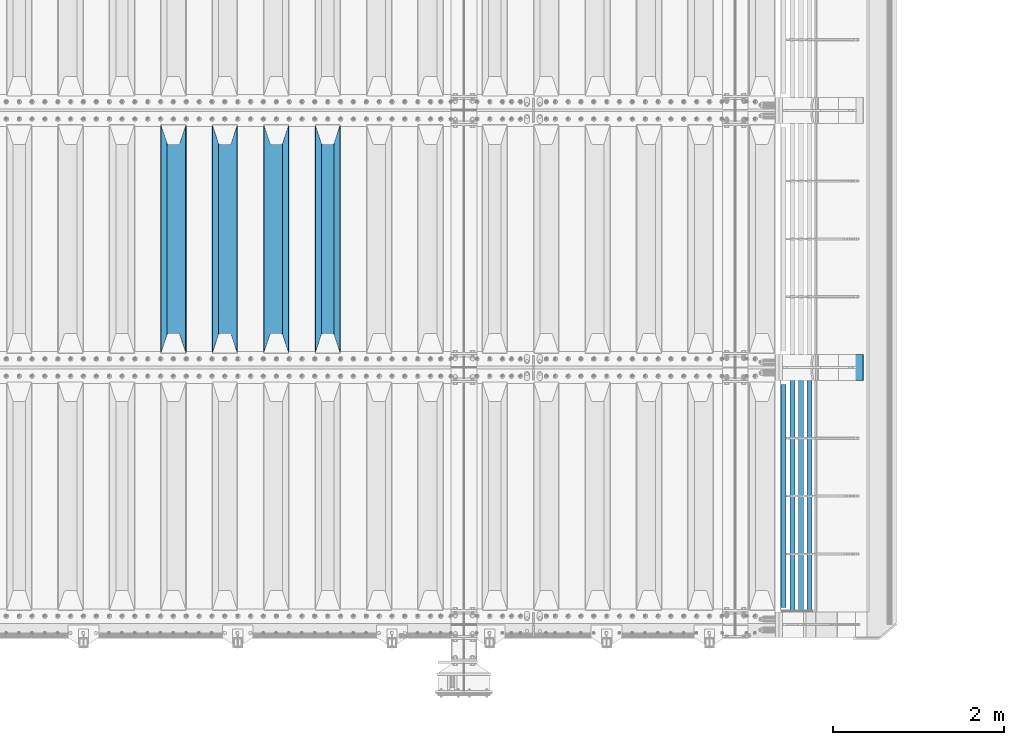
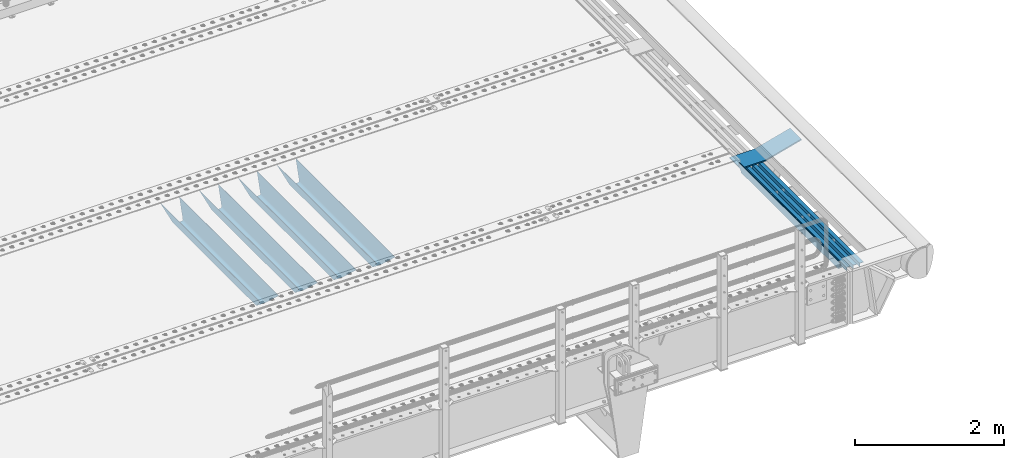
# One storey, part 109 of 240: 9 beams.
"""IFC2X3 building model written with IfcOpenShell, lengths in millimetres."""

from ifc_helpers import new_model, si_unit, frame, origin_with_axes, place, context, subcontext, project, spatial, faceted_brep, material, type_object, element, save


model = new_model("IFC2X3")

# Units and contexts
model_context = context("Model", 3, precision=1e-05, world=origin_with_axes())
body_context = subcontext(model_context, "Body", "Model", "MODEL_VIEW")
ifc_project = project(units=[si_unit("LENGTHUNIT", "METRE", prefix="MILLI"), si_unit("AREAUNIT", "SQUARE_METRE"), si_unit("VOLUMEUNIT", "CUBIC_METRE"), si_unit("MASSUNIT", "GRAM", prefix="KILO"), si_unit("TIMEUNIT", "SECOND"), si_unit("PLANEANGLEUNIT", "RADIAN"), si_unit("SOLIDANGLEUNIT", "STERADIAN"), si_unit("THERMODYNAMICTEMPERATUREUNIT", "DEGREE_CELSIUS"), si_unit("LUMINOUSINTENSITYUNIT", "LUMEN")], contexts=[model_context])

# Site, building, storey
site_placement = place(None, origin_with_axes())
site = spatial("IfcSite", under=ifc_project, at=site_placement, CompositionType="ELEMENT")
building_placement = place(site_placement, origin_with_axes())
building = spatial("IfcBuilding", under=site, at=building_placement, Name="Standard", CompositionType="ELEMENT")
storey_placement = place(building_placement, origin_with_axes())
storey = spatial("IfcBuildingStorey", under=building, at=storey_placement, Name="Undefined", CompositionType="ELEMENT", Elevation=0.0)

# Beams
ifc_material_1 = material(Name="STEEL/S355N")
beam_type_1 = type_object("IfcBeamType", PredefinedType="NOTDEFINED")
beam_1_placement = place(storey_placement, frame((51250.0, 27175.0, -115.0), z_axis=(0.0, 0.0, 1.0), x_axis=(0.0, 1.0, 0.0)))
element("IfcBeam", 1, at=beam_1_placement, inside=storey, type_object=beam_type_1, material=ifc_material_1, context=body_context, shape_type="Brep", body=[
    faceted_brep([(0.0, 150.0, 115.0), (0.0, 143.690000000002, 115.0), (2650.00000000297, 143.690000000002, 115.0), (2650.00000000297, 150.0, 115.0), (2650.00000000297, 142.059565218406, 110.000000003094), (2650.00000000297, 148.369565218403, 110.000000003094), (2441.90079219209, -80.1103600731149, -98.0992078077845), (2437.7588105432, -77.5672621345584, -102.241189456673), (2434.06523489747, -74.4080125315522, -105.934765102404), (2430.9108609509, -70.7102721255724, -109.089139048974), (2428.37322971128, -66.5649389910031, -111.626770288588), (2426.51472138055, -62.0739139532889, -113.485278619323), (2425.38102192092, -57.3475956567636, -114.618978078955), (2424.99999999987, -52.5021667386536, -115.0), (2424.99999999987, 52.5021667386536, -115.0), (2425.38102192092, 57.3475956567636, -114.618978078955), (2426.51472138055, 62.0739139532889, -113.485278619323), (2428.37322971128, 66.5649389910031, -111.626770288588), (2430.9108609509, 70.7102721255724, -109.089139048974), (2434.06523489747, 74.4080125315522, -105.934765102404), (2437.7588105432, 77.5672621345584, -102.241189456673), (2441.90079219209, 80.1103600731149, -98.0992078077846), (2446.38936140512, 81.9747917625791, -93.6106385947584), (2448.2494850041, 76.2713538057287, -91.7505149957729), (2444.62967112263, 74.76777986261, -95.3703288772456), (2441.28936334127, 72.7168944282894, -98.710636658607), (2438.31067330439, 70.1691124903809, -101.689326695487), (2435.76682334748, 67.1870637758839, -104.233176652398), (2433.72034654134, 63.8440531834931, -106.279653458539), (2432.22154950042, 60.2222587982324, -107.778450499454), (2431.30727574265, 56.4107117849126, -108.692724257221), (2430.99999999987, 52.5031078186876, -109.0), (2430.99999999987, -52.5031078186876, -109.0), (2431.30727574265, -56.4107117849126, -108.692724257221), (2432.22154950042, -60.2222587982324, -107.778450499454), (2433.72034654134, -63.8440531834931, -106.279653458539), (2435.76682334748, -67.1870637758839, -104.233176652398), (2438.31067330439, -70.1691124903809, -101.689326695487), (2441.28936334127, -72.7168944282894, -98.7106366586071), (2444.62967112263, -74.76777986261, -95.3703288772457), (2448.2494850041, -76.2713538057287, -91.7505149957729), (2650.00000000297, -142.059565218406, 110.000000003094), (2650.00000000297, -148.369565218403, 110.000000003094), (2446.38936140512, -81.9747917625791, -93.6106385947584), (2650.00000000297, -143.690000000002, 115.0), (2650.00000000297, -150.0, 115.0), (0.0, -143.690000000002, 115.0), (0.0, -150.0, 115.0), (0.0, -148.369565218258, 110.000000002667), (203.610638597427, -81.9747917625791, -93.6106385947584), (208.09920781045, -80.1103600731149, -98.0992078077845), (212.241189459342, -77.5672621345584, -102.241189456673), (215.93476510507, -74.4080125315522, -105.934765102404), (219.089139051641, -70.7102721255724, -109.089139048974), (221.626770291256, -66.5649389910031, -111.626770288588), (223.485278621989, -62.0739139532889, -113.485278619323), (224.618978081624, -57.3475956567636, -114.618978078955), (225.000000002663, -52.5021667386536, -115.0), (225.000000002663, 52.5021667386536, -115.0), (224.618978081624, 57.3475956567636, -114.618978078955), (223.485278621989, 62.0739139532889, -113.485278619323), (221.626770291256, 66.5649389910031, -111.626770288588), (219.089139051641, 70.7102721255724, -109.089139048974), (215.93476510507, 74.4080125315522, -105.934765102404), (212.241189459342, 77.5672621345584, -102.241189456673), (208.09920781045, 80.1103600731149, -98.0992078077846), (203.610638597427, 81.9747917625791, -93.6106385947584), (0.0, 148.369565218258, 110.000000002667), (0.0, 142.05956521826, 110.000000002667), (201.750514998439, 76.2713538057287, -91.7505149957729), (205.370328879908, 74.76777986261, -95.3703288772456), (208.710636661275, 72.7168944282894, -98.710636658607), (211.689326698153, 70.1691124903809, -101.689326695487), (214.233176655063, 67.1870637758839, -104.233176652398), (216.279653461206, 63.8440531834931, -106.279653458539), (217.778450502123, 60.2222587982324, -107.778450499454), (218.692724259887, 56.4107117849126, -108.692724257221), (219.000000002667, 52.5031078186876, -109.0), (219.000000002667, -52.5031078186876, -109.0), (218.692724259887, -56.4107117849126, -108.692724257221), (217.778450502123, -60.2222587982324, -107.778450499454), (216.279653461206, -63.8440531834931, -106.279653458539), (214.233176655063, -67.1870637758839, -104.233176652398), (211.689326698153, -70.1691124903809, -101.689326695487), (208.710636661275, -72.7168944282894, -98.7106366586071), (205.370328879915, -74.76777986261, -95.3703288772457), (201.750514998439, -76.2713538057287, -91.7505149957729), (0.0, -142.05956521826, 110.000000002667)], [[[0, 1, 2, 3]], [[3, 2, 4, 5]], [[6, 7, 8, 9, 10, 11, 12, 13, 14, 15, 16, 17, 18, 19, 20, 21, 22, 5, 4, 23, 24, 25, 26, 27, 28, 29, 30, 31, 32, 33, 34, 35, 36, 37, 38, 39, 40, 41, 42, 43]], [[44, 45, 42, 41]], [[46, 47, 45, 44]], [[43, 42, 45, 47, 48, 49]], [[6, 43, 49, 50]], [[7, 6, 50, 51]], [[8, 7, 51, 52]], [[9, 8, 52, 53]], [[10, 9, 53, 54]], [[11, 10, 54, 55]], [[12, 11, 55, 56]], [[13, 12, 56, 57]], [[14, 13, 57, 58]], [[15, 14, 58, 59]], [[16, 15, 59, 60]], [[17, 16, 60, 61]], [[18, 17, 61, 62]], [[19, 18, 62, 63]], [[20, 19, 63, 64]], [[21, 20, 64, 65]], [[22, 21, 65, 66]], [[0, 3, 5, 22, 66, 67]], [[1, 0, 67, 68]], [[23, 4, 2, 1, 68, 69]], [[24, 23, 69, 70]], [[25, 24, 70, 71]], [[26, 25, 71, 72]], [[27, 26, 72, 73]], [[28, 27, 73, 74]], [[29, 28, 74, 75]], [[30, 29, 75, 76]], [[31, 30, 76, 77]], [[32, 31, 77, 78]], [[33, 32, 78, 79]], [[34, 33, 79, 80]], [[35, 34, 80, 81]], [[36, 35, 81, 82]], [[37, 36, 82, 83]], [[38, 37, 83, 84]], [[39, 38, 84, 85]], [[40, 39, 85, 86]], [[46, 44, 41, 40, 86, 87]], [[47, 46, 87, 48]], [[86, 85, 84, 83, 82, 81, 80, 79, 78, 77, 76, 75, 74, 73, 72, 71, 70, 69, 68, 67, 66, 65, 64, 63, 62, 61, 60, 59, 58, 57, 56, 55, 54, 53, 52, 51, 50, 49, 48, 87]]]),
])
beam_2_placement = place(storey_placement, frame((50650.0, 27175.0, -115.0), z_axis=(0.0, 0.0, 1.0), x_axis=(0.0, 1.0, 0.0)))
element("IfcBeam", 2, at=beam_2_placement, inside=storey, type_object=beam_type_1, material=ifc_material_1, context=body_context, shape_type="Brep", body=[
    faceted_brep([(0.0, 150.0, 115.0), (0.0, 143.690000000002, 115.0), (2650.00000000297, 143.690000000002, 115.0), (2650.00000000297, 150.0, 115.0), (2650.00000000297, 142.059565218406, 110.000000003094), (2650.00000000297, 148.369565218403, 110.000000003094), (2441.90079219209, -80.1103600731149, -98.0992078077845), (2437.7588105432, -77.5672621345584, -102.241189456673), (2434.06523489747, -74.4080125315522, -105.934765102404), (2430.9108609509, -70.7102721255724, -109.089139048974), (2428.37322971128, -66.5649389910031, -111.626770288588), (2426.51472138055, -62.0739139532889, -113.485278619323), (2425.38102192092, -57.3475956567636, -114.618978078955), (2424.99999999987, -52.5021667386536, -115.0), (2424.99999999987, 52.5021667386536, -115.0), (2425.38102192092, 57.3475956567636, -114.618978078955), (2426.51472138055, 62.0739139532889, -113.485278619323), (2428.37322971128, 66.5649389910031, -111.626770288588), (2430.9108609509, 70.7102721255724, -109.089139048974), (2434.06523489747, 74.4080125315522, -105.934765102404), (2437.7588105432, 77.5672621345584, -102.241189456673), (2441.90079219209, 80.1103600731149, -98.0992078077846), (2446.38936140512, 81.9747917625791, -93.6106385947584), (2448.2494850041, 76.2713538057287, -91.7505149957729), (2444.62967112263, 74.76777986261, -95.3703288772456), (2441.28936334127, 72.7168944282894, -98.710636658607), (2438.31067330439, 70.1691124903809, -101.689326695487), (2435.76682334748, 67.1870637758839, -104.233176652398), (2433.72034654134, 63.8440531834931, -106.279653458539), (2432.22154950042, 60.2222587982324, -107.778450499454), (2431.30727574265, 56.4107117849126, -108.692724257221), (2430.99999999987, 52.5031078186876, -109.0), (2430.99999999987, -52.5031078186876, -109.0), (2431.30727574265, -56.4107117849126, -108.692724257221), (2432.22154950042, -60.2222587982324, -107.778450499454), (2433.72034654134, -63.8440531834931, -106.279653458539), (2435.76682334748, -67.1870637758839, -104.233176652398), (2438.31067330439, -70.1691124903809, -101.689326695487), (2441.28936334127, -72.7168944282894, -98.7106366586071), (2444.62967112263, -74.76777986261, -95.3703288772457), (2448.2494850041, -76.2713538057287, -91.7505149957729), (2650.00000000297, -142.059565218406, 110.000000003094), (2650.00000000297, -148.369565218403, 110.000000003094), (2446.38936140512, -81.9747917625791, -93.6106385947584), (2650.00000000297, -143.690000000002, 115.0), (2650.00000000297, -150.0, 115.0), (0.0, -143.690000000002, 115.0), (0.0, -150.0, 115.0), (0.0, -148.369565218258, 110.000000002667), (203.610638597427, -81.9747917625791, -93.6106385947584), (208.09920781045, -80.1103600731149, -98.0992078077845), (212.241189459342, -77.5672621345584, -102.241189456673), (215.93476510507, -74.4080125315522, -105.934765102404), (219.089139051641, -70.7102721255724, -109.089139048974), (221.626770291256, -66.5649389910031, -111.626770288588), (223.485278621989, -62.0739139532889, -113.485278619323), (224.618978081624, -57.3475956567636, -114.618978078955), (225.000000002663, -52.5021667386536, -115.0), (225.000000002663, 52.5021667386536, -115.0), (224.618978081624, 57.3475956567636, -114.618978078955), (223.485278621989, 62.0739139532889, -113.485278619323), (221.626770291256, 66.5649389910031, -111.626770288588), (219.089139051641, 70.7102721255724, -109.089139048974), (215.93476510507, 74.4080125315522, -105.934765102404), (212.241189459342, 77.5672621345584, -102.241189456673), (208.09920781045, 80.1103600731149, -98.0992078077846), (203.610638597427, 81.9747917625791, -93.6106385947584), (0.0, 148.369565218258, 110.000000002667), (0.0, 142.05956521826, 110.000000002667), (201.750514998439, 76.2713538057287, -91.7505149957729), (205.370328879908, 74.76777986261, -95.3703288772456), (208.710636661275, 72.7168944282894, -98.710636658607), (211.689326698153, 70.1691124903809, -101.689326695487), (214.233176655063, 67.1870637758839, -104.233176652398), (216.279653461206, 63.8440531834931, -106.279653458539), (217.778450502123, 60.2222587982324, -107.778450499454), (218.692724259887, 56.4107117849126, -108.692724257221), (219.000000002667, 52.5031078186876, -109.0), (219.000000002667, -52.5031078186876, -109.0), (218.692724259887, -56.4107117849126, -108.692724257221), (217.778450502123, -60.2222587982324, -107.778450499454), (216.279653461206, -63.8440531834931, -106.279653458539), (214.233176655063, -67.1870637758839, -104.233176652398), (211.689326698153, -70.1691124903809, -101.689326695487), (208.710636661275, -72.7168944282894, -98.7106366586071), (205.370328879915, -74.76777986261, -95.3703288772457), (201.750514998439, -76.2713538057287, -91.7505149957729), (0.0, -142.05956521826, 110.000000002667)], [[[0, 1, 2, 3]], [[3, 2, 4, 5]], [[6, 7, 8, 9, 10, 11, 12, 13, 14, 15, 16, 17, 18, 19, 20, 21, 22, 5, 4, 23, 24, 25, 26, 27, 28, 29, 30, 31, 32, 33, 34, 35, 36, 37, 38, 39, 40, 41, 42, 43]], [[44, 45, 42, 41]], [[46, 47, 45, 44]], [[43, 42, 45, 47, 48, 49]], [[6, 43, 49, 50]], [[7, 6, 50, 51]], [[8, 7, 51, 52]], [[9, 8, 52, 53]], [[10, 9, 53, 54]], [[11, 10, 54, 55]], [[12, 11, 55, 56]], [[13, 12, 56, 57]], [[14, 13, 57, 58]], [[15, 14, 58, 59]], [[16, 15, 59, 60]], [[17, 16, 60, 61]], [[18, 17, 61, 62]], [[19, 18, 62, 63]], [[20, 19, 63, 64]], [[21, 20, 64, 65]], [[22, 21, 65, 66]], [[0, 3, 5, 22, 66, 67]], [[1, 0, 67, 68]], [[23, 4, 2, 1, 68, 69]], [[24, 23, 69, 70]], [[25, 24, 70, 71]], [[26, 25, 71, 72]], [[27, 26, 72, 73]], [[28, 27, 73, 74]], [[29, 28, 74, 75]], [[30, 29, 75, 76]], [[31, 30, 76, 77]], [[32, 31, 77, 78]], [[33, 32, 78, 79]], [[34, 33, 79, 80]], [[35, 34, 80, 81]], [[36, 35, 81, 82]], [[37, 36, 82, 83]], [[38, 37, 83, 84]], [[39, 38, 84, 85]], [[40, 39, 85, 86]], [[46, 44, 41, 40, 86, 87]], [[47, 46, 87, 48]], [[86, 85, 84, 83, 82, 81, 80, 79, 78, 77, 76, 75, 74, 73, 72, 71, 70, 69, 68, 67, 66, 65, 64, 63, 62, 61, 60, 59, 58, 57, 56, 55, 54, 53, 52, 51, 50, 49, 48, 87]]]),
])
beam_3_placement = place(storey_placement, frame((50050.0, 27175.0, -115.0), z_axis=(0.0, 0.0, 1.0), x_axis=(0.0, 1.0, 0.0)))
element("IfcBeam", 3, at=beam_3_placement, inside=storey, type_object=beam_type_1, material=ifc_material_1, context=body_context, shape_type="Brep", body=[
    faceted_brep([(0.0, 150.0, 115.0), (0.0, 143.690000000002, 115.0), (2650.00000000297, 143.690000000002, 115.0), (2650.00000000297, 150.0, 115.0), (2650.00000000297, 142.059565218406, 110.000000003094), (2650.00000000297, 148.369565218403, 110.000000003094), (2441.90079219209, -80.1103600731149, -98.0992078077845), (2437.7588105432, -77.5672621345584, -102.241189456673), (2434.06523489747, -74.4080125315522, -105.934765102404), (2430.9108609509, -70.7102721255724, -109.089139048974), (2428.37322971128, -66.5649389910031, -111.626770288588), (2426.51472138055, -62.0739139532889, -113.485278619323), (2425.38102192092, -57.3475956567636, -114.618978078955), (2424.99999999987, -52.5021667386536, -115.0), (2424.99999999987, 52.5021667386536, -115.0), (2425.38102192092, 57.3475956567636, -114.618978078955), (2426.51472138055, 62.0739139532889, -113.485278619323), (2428.37322971128, 66.5649389910031, -111.626770288588), (2430.9108609509, 70.7102721255724, -109.089139048974), (2434.06523489747, 74.4080125315522, -105.934765102404), (2437.7588105432, 77.5672621345584, -102.241189456673), (2441.90079219209, 80.1103600731149, -98.0992078077846), (2446.38936140512, 81.9747917625791, -93.6106385947584), (2448.2494850041, 76.2713538057287, -91.7505149957729), (2444.62967112263, 74.76777986261, -95.3703288772456), (2441.28936334127, 72.7168944282894, -98.710636658607), (2438.31067330439, 70.1691124903809, -101.689326695487), (2435.76682334748, 67.1870637758839, -104.233176652398), (2433.72034654134, 63.8440531834931, -106.279653458539), (2432.22154950042, 60.2222587982324, -107.778450499454), (2431.30727574265, 56.4107117849126, -108.692724257221), (2430.99999999987, 52.5031078186876, -109.0), (2430.99999999987, -52.5031078186876, -109.0), (2431.30727574265, -56.4107117849126, -108.692724257221), (2432.22154950042, -60.2222587982324, -107.778450499454), (2433.72034654134, -63.8440531834931, -106.279653458539), (2435.76682334748, -67.1870637758839, -104.233176652398), (2438.31067330439, -70.1691124903809, -101.689326695487), (2441.28936334127, -72.7168944282894, -98.7106366586071), (2444.62967112263, -74.76777986261, -95.3703288772457), (2448.2494850041, -76.2713538057287, -91.7505149957729), (2650.00000000297, -142.059565218406, 110.000000003094), (2650.00000000297, -148.369565218403, 110.000000003094), (2446.38936140512, -81.9747917625791, -93.6106385947584), (2650.00000000297, -143.690000000002, 115.0), (2650.00000000297, -150.0, 115.0), (0.0, -143.690000000002, 115.0), (0.0, -150.0, 115.0), (0.0, -148.369565218258, 110.000000002667), (203.610638597427, -81.9747917625791, -93.6106385947584), (208.09920781045, -80.1103600731149, -98.0992078077845), (212.241189459342, -77.5672621345584, -102.241189456673), (215.93476510507, -74.4080125315522, -105.934765102404), (219.089139051641, -70.7102721255724, -109.089139048974), (221.626770291256, -66.5649389910031, -111.626770288588), (223.485278621989, -62.0739139532889, -113.485278619323), (224.618978081624, -57.3475956567636, -114.618978078955), (225.000000002663, -52.5021667386536, -115.0), (225.000000002663, 52.5021667386536, -115.0), (224.618978081624, 57.3475956567636, -114.618978078955), (223.485278621989, 62.0739139532889, -113.485278619323), (221.626770291256, 66.5649389910031, -111.626770288588), (219.089139051641, 70.7102721255724, -109.089139048974), (215.93476510507, 74.4080125315522, -105.934765102404), (212.241189459342, 77.5672621345584, -102.241189456673), (208.09920781045, 80.1103600731149, -98.0992078077846), (203.610638597427, 81.9747917625791, -93.6106385947584), (0.0, 148.369565218258, 110.000000002667), (0.0, 142.05956521826, 110.000000002667), (201.750514998439, 76.2713538057287, -91.7505149957729), (205.370328879908, 74.76777986261, -95.3703288772456), (208.710636661275, 72.7168944282894, -98.710636658607), (211.689326698153, 70.1691124903809, -101.689326695487), (214.233176655063, 67.1870637758839, -104.233176652398), (216.279653461206, 63.8440531834931, -106.279653458539), (217.778450502123, 60.2222587982324, -107.778450499454), (218.692724259887, 56.4107117849126, -108.692724257221), (219.000000002667, 52.5031078186876, -109.0), (219.000000002667, -52.5031078186876, -109.0), (218.692724259887, -56.4107117849126, -108.692724257221), (217.778450502123, -60.2222587982324, -107.778450499454), (216.279653461206, -63.8440531834931, -106.279653458539), (214.233176655063, -67.1870637758839, -104.233176652398), (211.689326698153, -70.1691124903809, -101.689326695487), (208.710636661275, -72.7168944282894, -98.7106366586071), (205.370328879915, -74.76777986261, -95.3703288772457), (201.750514998439, -76.2713538057287, -91.7505149957729), (0.0, -142.05956521826, 110.000000002667)], [[[0, 1, 2, 3]], [[3, 2, 4, 5]], [[6, 7, 8, 9, 10, 11, 12, 13, 14, 15, 16, 17, 18, 19, 20, 21, 22, 5, 4, 23, 24, 25, 26, 27, 28, 29, 30, 31, 32, 33, 34, 35, 36, 37, 38, 39, 40, 41, 42, 43]], [[44, 45, 42, 41]], [[46, 47, 45, 44]], [[43, 42, 45, 47, 48, 49]], [[6, 43, 49, 50]], [[7, 6, 50, 51]], [[8, 7, 51, 52]], [[9, 8, 52, 53]], [[10, 9, 53, 54]], [[11, 10, 54, 55]], [[12, 11, 55, 56]], [[13, 12, 56, 57]], [[14, 13, 57, 58]], [[15, 14, 58, 59]], [[16, 15, 59, 60]], [[17, 16, 60, 61]], [[18, 17, 61, 62]], [[19, 18, 62, 63]], [[20, 19, 63, 64]], [[21, 20, 64, 65]], [[22, 21, 65, 66]], [[0, 3, 5, 22, 66, 67]], [[1, 0, 67, 68]], [[23, 4, 2, 1, 68, 69]], [[24, 23, 69, 70]], [[25, 24, 70, 71]], [[26, 25, 71, 72]], [[27, 26, 72, 73]], [[28, 27, 73, 74]], [[29, 28, 74, 75]], [[30, 29, 75, 76]], [[31, 30, 76, 77]], [[32, 31, 77, 78]], [[33, 32, 78, 79]], [[34, 33, 79, 80]], [[35, 34, 80, 81]], [[36, 35, 81, 82]], [[37, 36, 82, 83]], [[38, 37, 83, 84]], [[39, 38, 84, 85]], [[40, 39, 85, 86]], [[46, 44, 41, 40, 86, 87]], [[47, 46, 87, 48]], [[86, 85, 84, 83, 82, 81, 80, 79, 78, 77, 76, 75, 74, 73, 72, 71, 70, 69, 68, 67, 66, 65, 64, 63, 62, 61, 60, 59, 58, 57, 56, 55, 54, 53, 52, 51, 50, 49, 48, 87]]]),
])
beam_4_placement = place(storey_placement, frame((49450.0, 27175.0, -115.0), z_axis=(0.0, 0.0, 1.0), x_axis=(0.0, 1.0, 0.0)))
element("IfcBeam", 4, at=beam_4_placement, inside=storey, type_object=beam_type_1, material=ifc_material_1, context=body_context, shape_type="Brep", body=[
    faceted_brep([(0.0, 150.0, 115.0), (0.0, 143.690000000002, 115.0), (2650.00000000297, 143.690000000002, 115.0), (2650.00000000297, 150.0, 115.0), (2650.00000000297, 142.059565218406, 110.000000003094), (2650.00000000297, 148.369565218403, 110.000000003094), (2441.90079219209, -80.1103600731149, -98.0992078077845), (2437.7588105432, -77.5672621345584, -102.241189456673), (2434.06523489747, -74.4080125315522, -105.934765102404), (2430.9108609509, -70.7102721255724, -109.089139048974), (2428.37322971128, -66.5649389910031, -111.626770288588), (2426.51472138055, -62.0739139532889, -113.485278619323), (2425.38102192092, -57.3475956567636, -114.618978078955), (2424.99999999987, -52.5021667386536, -115.0), (2424.99999999987, 52.5021667386536, -115.0), (2425.38102192092, 57.3475956567636, -114.618978078955), (2426.51472138055, 62.0739139532889, -113.485278619323), (2428.37322971128, 66.5649389910031, -111.626770288588), (2430.9108609509, 70.7102721255724, -109.089139048974), (2434.06523489747, 74.4080125315522, -105.934765102404), (2437.7588105432, 77.5672621345584, -102.241189456673), (2441.90079219209, 80.1103600731149, -98.0992078077846), (2446.38936140512, 81.9747917625791, -93.6106385947584), (2448.2494850041, 76.2713538057287, -91.7505149957729), (2444.62967112263, 74.76777986261, -95.3703288772456), (2441.28936334127, 72.7168944282894, -98.710636658607), (2438.31067330439, 70.1691124903809, -101.689326695487), (2435.76682334748, 67.1870637758839, -104.233176652398), (2433.72034654134, 63.8440531834931, -106.279653458539), (2432.22154950042, 60.2222587982324, -107.778450499454), (2431.30727574265, 56.4107117849126, -108.692724257221), (2430.99999999987, 52.5031078186876, -109.0), (2430.99999999987, -52.5031078186876, -109.0), (2431.30727574265, -56.4107117849126, -108.692724257221), (2432.22154950042, -60.2222587982324, -107.778450499454), (2433.72034654134, -63.8440531834931, -106.279653458539), (2435.76682334748, -67.1870637758839, -104.233176652398), (2438.31067330439, -70.1691124903809, -101.689326695487), (2441.28936334127, -72.7168944282894, -98.7106366586071), (2444.62967112263, -74.76777986261, -95.3703288772457), (2448.2494850041, -76.2713538057287, -91.7505149957729), (2650.00000000297, -142.059565218406, 110.000000003094), (2650.00000000297, -148.369565218403, 110.000000003094), (2446.38936140512, -81.9747917625791, -93.6106385947584), (2650.00000000297, -143.690000000002, 115.0), (2650.00000000297, -150.0, 115.0), (0.0, -143.690000000002, 115.0), (0.0, -150.0, 115.0), (0.0, -148.369565218258, 110.000000002667), (203.610638597427, -81.9747917625791, -93.6106385947584), (208.09920781045, -80.1103600731149, -98.0992078077845), (212.241189459342, -77.5672621345584, -102.241189456673), (215.93476510507, -74.4080125315522, -105.934765102404), (219.089139051641, -70.7102721255724, -109.089139048974), (221.626770291256, -66.5649389910031, -111.626770288588), (223.485278621989, -62.0739139532889, -113.485278619323), (224.618978081624, -57.3475956567636, -114.618978078955), (225.000000002663, -52.5021667386536, -115.0), (225.000000002663, 52.5021667386536, -115.0), (224.618978081624, 57.3475956567636, -114.618978078955), (223.485278621989, 62.0739139532889, -113.485278619323), (221.626770291256, 66.5649389910031, -111.626770288588), (219.089139051641, 70.7102721255724, -109.089139048974), (215.93476510507, 74.4080125315522, -105.934765102404), (212.241189459342, 77.5672621345584, -102.241189456673), (208.09920781045, 80.1103600731149, -98.0992078077846), (203.610638597427, 81.9747917625791, -93.6106385947584), (0.0, 148.369565218258, 110.000000002667), (0.0, 142.05956521826, 110.000000002667), (201.750514998439, 76.2713538057287, -91.7505149957729), (205.370328879908, 74.76777986261, -95.3703288772456), (208.710636661275, 72.7168944282894, -98.710636658607), (211.689326698153, 70.1691124903809, -101.689326695487), (214.233176655063, 67.1870637758839, -104.233176652398), (216.279653461206, 63.8440531834931, -106.279653458539), (217.778450502123, 60.2222587982324, -107.778450499454), (218.692724259887, 56.4107117849126, -108.692724257221), (219.000000002667, 52.5031078186876, -109.0), (219.000000002667, -52.5031078186876, -109.0), (218.692724259887, -56.4107117849126, -108.692724257221), (217.778450502123, -60.2222587982324, -107.778450499454), (216.279653461206, -63.8440531834931, -106.279653458539), (214.233176655063, -67.1870637758839, -104.233176652398), (211.689326698153, -70.1691124903809, -101.689326695487), (208.710636661275, -72.7168944282894, -98.7106366586071), (205.370328879915, -74.76777986261, -95.3703288772457), (201.750514998439, -76.2713538057287, -91.7505149957729), (0.0, -142.05956521826, 110.000000002667)], [[[0, 1, 2, 3]], [[3, 2, 4, 5]], [[6, 7, 8, 9, 10, 11, 12, 13, 14, 15, 16, 17, 18, 19, 20, 21, 22, 5, 4, 23, 24, 25, 26, 27, 28, 29, 30, 31, 32, 33, 34, 35, 36, 37, 38, 39, 40, 41, 42, 43]], [[44, 45, 42, 41]], [[46, 47, 45, 44]], [[43, 42, 45, 47, 48, 49]], [[6, 43, 49, 50]], [[7, 6, 50, 51]], [[8, 7, 51, 52]], [[9, 8, 52, 53]], [[10, 9, 53, 54]], [[11, 10, 54, 55]], [[12, 11, 55, 56]], [[13, 12, 56, 57]], [[14, 13, 57, 58]], [[15, 14, 58, 59]], [[16, 15, 59, 60]], [[17, 16, 60, 61]], [[18, 17, 61, 62]], [[19, 18, 62, 63]], [[20, 19, 63, 64]], [[21, 20, 64, 65]], [[22, 21, 65, 66]], [[0, 3, 5, 22, 66, 67]], [[1, 0, 67, 68]], [[23, 4, 2, 1, 68, 69]], [[24, 23, 69, 70]], [[25, 24, 70, 71]], [[26, 25, 71, 72]], [[27, 26, 72, 73]], [[28, 27, 73, 74]], [[29, 28, 74, 75]], [[30, 29, 75, 76]], [[31, 30, 76, 77]], [[32, 31, 77, 78]], [[33, 32, 78, 79]], [[34, 33, 79, 80]], [[35, 34, 80, 81]], [[36, 35, 81, 82]], [[37, 36, 82, 83]], [[38, 37, 83, 84]], [[39, 38, 84, 85]], [[40, 39, 85, 86]], [[46, 44, 41, 40, 86, 87]], [[47, 46, 87, 48]], [[86, 85, 84, 83, 82, 81, 80, 79, 78, 77, 76, 75, 74, 73, 72, 71, 70, 69, 68, 67, 66, 65, 64, 63, 62, 61, 60, 59, 58, 57, 56, 55, 54, 53, 52, 51, 50, 49, 48, 87]]]),
])
ifc_material_2 = material(Name="STEEL/S355J2")
beam_type_2 = type_object("IfcBeamType", PredefinedType="NOTDEFINED")
beam_5_placement = place(storey_placement, frame((56564.5025260065, 24150.0, -124.999999999968), z_axis=(0.0, 0.0, 1.0), x_axis=(0.0, 1.0, 0.0)))
element("IfcBeam", 5, at=beam_5_placement, inside=storey, type_object=beam_type_2, material=ifc_material_2, context=body_context, shape_type="Brep", body=[
    faceted_brep([(2700.0, 22.5, -15.0), (2684.54915028125, 22.5, -17.4471741852423), (2684.54915028125, 32.4999999999927, -17.4471741852423), (2700.0, 32.5, -15.0), (2670.61073738538, 22.5, -24.5491502812526), (2670.61073738538, 32.4999999999927, -24.5491502812526), (2659.54915028125, 22.5, -35.6107373853764), (2659.54915028125, 32.4999999999927, -35.6107373853764), (2652.44717418524, 22.5, -49.5491502812526), (2652.44717418524, 32.4999999999927, -49.5491502812526), (2651.58384440325, -32.5, -55.0), (2650.0, -32.5, -65.0), (2650.0, 32.5, -65.0), (2651.58384440325, 22.5, -55.0), (0.0, 32.5, 65.0), (0.0, 22.5, 65.0), (2700.0, 22.5, 65.0), (2700.0, 32.5, 65.0), (0.0, 32.5, -15.0), (0.0, 22.5, -15.0), (15.4508497187489, 32.5, -17.4471741852423), (15.4508497187489, 22.5, -17.4471741852423), (29.3892626146226, 32.5, -24.5491502812526), (29.3892626146226, 22.5, -24.5491502812526), (40.4508497187489, 32.5, -35.6107373853763), (40.4508497187489, 22.5, -35.6107373853763), (47.5528258147569, 32.5, -49.5491502812526), (47.5528258147569, 22.5, -49.5491502812526), (50.0, -32.5, -65.0), (48.4161555967512, -32.5, -55.0), (48.4161555967512, 22.5, -55.0), (50.0, 32.5, -65.0)], [[[0, 1, 2, 3]], [[4, 5, 2, 1]], [[6, 7, 5, 4]], [[8, 9, 7, 6]], [[10, 11, 12, 9, 8, 13]], [[14, 15, 16, 17]], [[15, 14, 18, 19]], [[19, 18, 20, 21]], [[21, 20, 22, 23]], [[23, 22, 24, 25]], [[25, 24, 26, 27]], [[28, 29, 30, 27, 26, 31]], [[30, 29, 10, 13]], [[16, 15, 19, 21, 23, 25, 27, 30, 13, 8, 6, 4, 1, 0]], [[17, 16, 0, 3]], [[5, 7, 9, 12, 31, 26, 24, 22, 20, 18, 14, 17, 3, 2]], [[28, 31, 12, 11]], [[29, 28, 11, 10]]]),
])
beam_type_3 = type_object("IfcBeamType", PredefinedType="NOTDEFINED")
beam_6_placement = place(storey_placement, frame((56556.9988298908, 27000.0, -169.999999999995), z_axis=(0.0, -1.0, 0.0), x_axis=(1.0, 0.0, 0.0)))
element("IfcBeam", 6, at=beam_6_placement, inside=storey, type_object=beam_type_3, material=ifc_material_1, context=body_context, shape_type="Brep", body=[
    faceted_brep([(0.0, 10.0, -150.0), (0.0, 10.0, 150.0), (356.495387467709, 10.0, 150.0), (356.495387467716, 10.0000000000045, -150.0), (0.0, -10.0, 150.0), (0.0, -10.0, -150.0), (356.495387467709, -10.0, -150.0), (356.495387467709, -10.0, 150.0), (382.770279632619, 11.7334369042659, 150.0), (382.770279632619, 11.7334369042659, -150.0), (385.397768849085, -8.09321940530759, -150.0), (385.397768849085, -8.09321940530759, 150.0), (413.799145685371, -2.40593045938311, -150.0), (413.799145685371, -2.40593045938311, 150.0), (408.589713120156, 16.903699582373, 150.0), (408.589713119858, 16.9036995827009, -150.0), (938.999999999978, 160.0, 150.0), (938.999999999978, 160.0, -150.0), (944.209432565192, 140.69036995827, 150.0), (944.209432565192, 140.69036995827, -150.0)], [[[0, 1, 2, 3]], [[4, 5, 6, 7]], [[5, 4, 1, 0]], [[3, 2, 8, 9]], [[7, 6, 10, 11]], [[10, 12, 13, 11]], [[8, 14, 15, 9]], [[15, 14, 16, 17]], [[14, 8, 2, 1, 4, 7, 11, 13, 18, 16]], [[13, 12, 19, 18]], [[12, 10, 6, 5, 0, 3, 9, 15, 17, 19]], [[18, 19, 17, 16]]]),
])
beam_type_4 = type_object("IfcBeamType", PredefinedType="NOTDEFINED")
for number, where, z_axis, x_axis in (
    (7, (56872.0024147167, 26869.999997659, -210.000211453656), (0.0, 0.0, -1.0), (0.0, -1.0, 0.0)),
    (8, (56772.0024147167, 26869.999997659, -210.000211453656), (0.0, 0.0, -1.0), (0.0, -1.0, 0.0)),
    (9, (56672.002414716, 26869.999997659, -210.000211453712), (0.0, 0.0, -1.0), (0.0, -1.0, 0.0)),
):
    element("IfcBeam", number, at=place(storey_placement, frame(where, z_axis=z_axis, x_axis=x_axis)), inside=storey, type_object=beam_type_4, material=ifc_material_2, context=body_context, shape_type="Brep", body=[
        faceted_brep([(-3.63797880709171e-12, 29.9999999999927, -29.9999999999999), (-3.63797880709171e-12, 29.9999999999927, 30.0000000000001), (2710.00000000001, 29.9999999999927, 30.0), (2710.00000000001, 29.9999999999927, -30.0), (-3.63797880709171e-12, 23.9999999999927, 30.0), (2710.00000000001, 23.9999999999927, 30.0), (-3.63797880709171e-12, 23.9999999999927, -24.0), (2710.00000000001, 23.9999999999927, -24.0), (-7.27595761418343e-12, -30.0000000000073, -24.0), (2710.00000000001, -30.0000000000073, -24.0), (-3.63797880709171e-12, -30.0000000000073, -30.0), (2710.00000000001, -30.0000000000073, -30.0)], [[[0, 1, 2, 3]], [[1, 4, 5, 2]], [[4, 6, 7, 5]], [[6, 8, 9, 7]], [[8, 10, 11, 9]], [[10, 0, 3, 11]], [[5, 7, 9, 11, 3, 2]], [[10, 8, 6, 4, 1, 0]]]),
    ])

save(model, "model.ifc")
